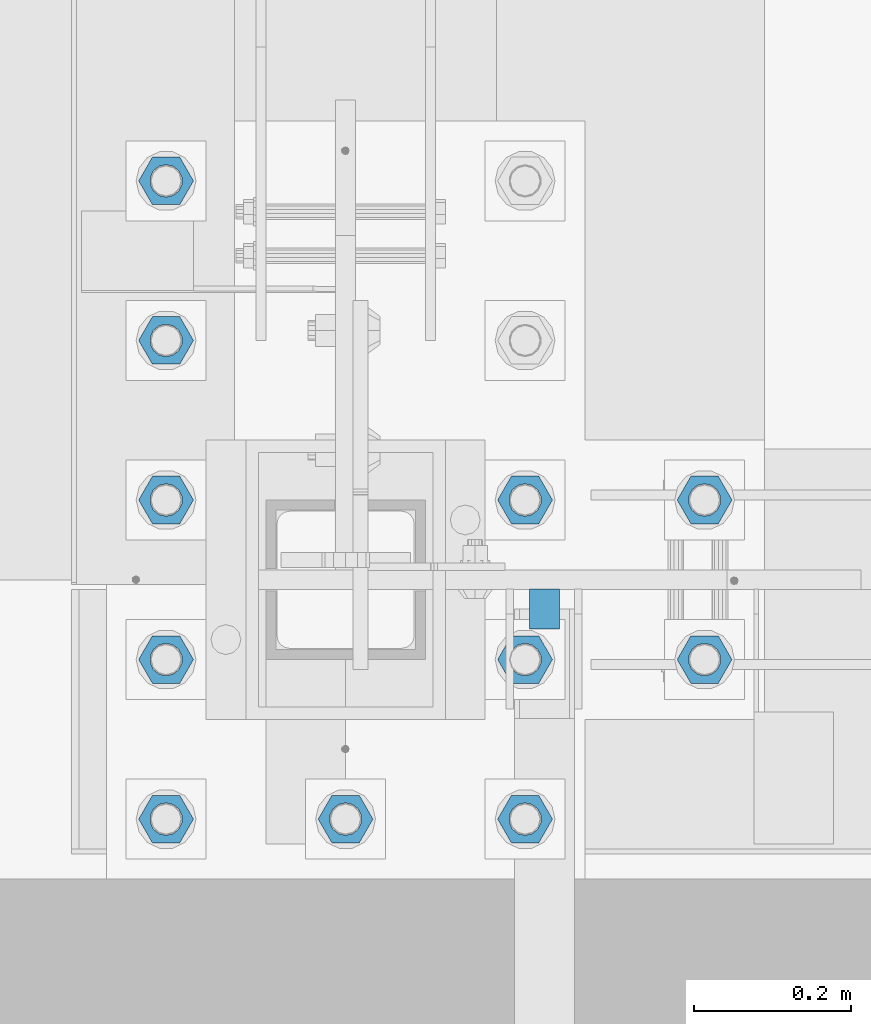
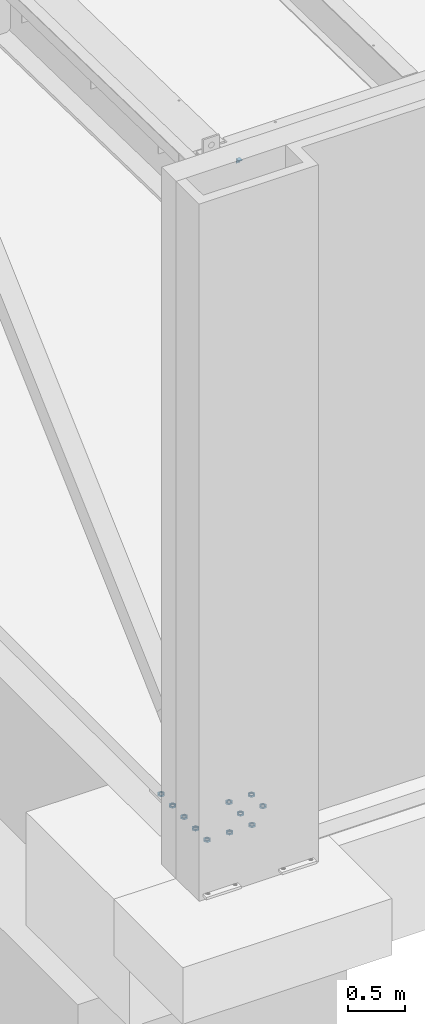
# One storey, part 1386 of 1763: 12 beams, 2 elements without a shape of their own.
"""IFC2X3 building model written with IfcOpenShell, lengths in millimetres."""

from ifc_helpers import new_model, si_unit, frame, origin_with_axes, place, context, subcontext, project, spatial, faceted_brep, material, type_object, element, aggregate, save


model = new_model("IFC2X3")

# Units and contexts
model_context = context("Model", 3, precision=1e-05, world=origin_with_axes())
body_context = subcontext(model_context, "Body", "Model", "MODEL_VIEW")
ifc_project = project(units=[si_unit("LENGTHUNIT", "METRE", prefix="MILLI"), si_unit("AREAUNIT", "SQUARE_METRE"), si_unit("VOLUMEUNIT", "CUBIC_METRE"), si_unit("MASSUNIT", "GRAM", prefix="KILO"), si_unit("TIMEUNIT", "SECOND"), si_unit("PLANEANGLEUNIT", "RADIAN"), si_unit("SOLIDANGLEUNIT", "STERADIAN"), si_unit("THERMODYNAMICTEMPERATUREUNIT", "DEGREE_CELSIUS"), si_unit("LUMINOUSINTENSITYUNIT", "LUMEN")], contexts=[model_context])

# Site, building, storey
site_placement = place(None, origin_with_axes())
site = spatial("IfcSite", under=ifc_project, at=site_placement, CompositionType="ELEMENT")
building_placement = place(site_placement, origin_with_axes())
building = spatial("IfcBuilding", under=site, at=building_placement, Name="Undefined", CompositionType="ELEMENT")
storey_placement = place(building_placement, origin_with_axes())
storey = spatial("IfcBuildingStorey", under=building, at=storey_placement, Name="Undefined", CompositionType="ELEMENT", Elevation=0.0)

# Assembly, beam
assembly_1_placement = place(storey_placement, origin_with_axes())
assembly_1 = element("IfcElementAssembly", 1, at=assembly_1_placement, inside=storey, Name="BEAM", AssemblyPlace="NOTDEFINED", PredefinedType="RIGID_FRAME")
ifc_material_1 = material(Name="STEEL/A36")
beam_type_1 = type_object("IfcBeamType", Name="L2X2X1/4", PredefinedType="NOTDEFINED")
beam_1_placement = place(assembly_1_placement, frame((-87102.9311228713, -13753.3060686171, 12052.3), z_axis=(0.0, 0.0, -1.0), x_axis=(-1.0, 0.0, 0.0)))
beam_1 = element("IfcBeam", 2, at=beam_1_placement, type_object=beam_type_1, material=ifc_material_1, Name="BEAM", ObjectType="L2X2X1/4", context=body_context, shape_type="Brep", body=[
    faceted_brep([(-1.45519152283669e-11, 25.4000000000015, -25.3999999999869), (1.45519152283669e-11, 25.4000000000015, 25.3999999999796), (38.0999999999913, 25.3999999999996, 25.3999999999996), (38.0999999999913, 25.3999999999996, -25.3999999999996), (1.45519152283669e-11, 19.0499999999993, 25.3999999999796), (38.0999999999913, 19.0499999999993, 25.3999999999996), (-7.27595761418343e-12, 19.0499999999993, -19.0499999999956), (38.0999999999913, 19.0499999999993, -19.0499999999993), (-7.27595761418343e-12, -25.4000000000015, -19.0499999999956), (38.0999999999913, -25.3999999999996, -19.0499999999993), (-1.45519152283669e-11, -25.4000000000015, -25.3999999999869), (38.0999999999913, -25.3999999999996, -25.3999999999996)], [[[0, 1, 2, 3]], [[1, 4, 5, 2]], [[4, 6, 7, 5]], [[6, 8, 9, 7]], [[8, 10, 11, 9]], [[10, 0, 3, 11]], [[5, 7, 9, 11, 3, 2]], [[10, 8, 6, 4, 1, 0]]]),
])
aggregate(assembly_1, [beam_1])

# Assembly, beams
assembly_2_placement = place(storey_placement, origin_with_axes())
assembly_2 = element("IfcElementAssembly", 3, at=assembly_2_placement, inside=storey, Name="TEMPLATE", AssemblyPlace="NOTDEFINED", PredefinedType="RIGID_FRAME")
ifc_material_2 = material(Name="STEEL/A563")
beam_type_2 = type_object("IfcBeamType", Name="1-1/2 DIA. HALF_NUT", PredefinedType="NOTDEFINED")
beam_2_placement = place(assembly_2_placement, frame((-86918.2372736984, -13614.4, 5080.00000000001), z_axis=(0.0, 1.0, 0.0), x_axis=(0.0, 0.0, -1.0)))
beam_2 = element("IfcBeam", 4, at=beam_2_placement, type_object=beam_type_2, material=ifc_material_2, Name="NUT", ObjectType="1-1/2 DIA. HALF_NUT", context=body_context, shape_type="Brep", body=[
    faceted_brep([(0.0, -34.9199981689453, 0.0), (0.0, -17.4599990844727, -30.25), (19.0499999999993, -17.4599990844727, -30.25), (19.0499999999993, -34.9199981689453, 0.0), (0.0, 17.4599990844727, -30.25), (19.0499999999993, 17.4599990844727, -30.25), (0.0, 34.9199981689453, 0.0), (19.0499999999993, 34.9199981689453, 0.0), (0.0, 17.4599990844727, 30.25), (19.0499999999993, 17.4599990844727, 30.25), (0.0, -17.4599990844727, 30.25), (19.0499999999993, -17.4599990844727, 30.25), (0.0, 0.0, 20.6399993896484), (0.0, 8.95536011056538, 18.5959968835978), (19.0499999999993, 8.95536011056538, 18.5959968835978), (19.0499999999993, 0.0, 20.6399993896484), (0.0, 16.1370013209453, 12.8688291298167), (19.0499999999993, 16.1370013209453, 12.8688291298167), (0.0, 20.1225115123816, 4.59283194104137), (19.0499999999993, 20.1225115123816, 4.59283194104137), (0.0, 20.1225115123816, -4.59283194104319), (19.0499999999993, 20.1225115123816, -4.59283194104319), (0.0, 16.1370013209453, -12.8688291298167), (19.0499999999993, 16.1370013209453, -12.8688291298167), (0.0, 8.95536011056538, -18.5959968835978), (19.0499999999993, 8.95536011056538, -18.5959968835978), (0.0, 0.0, -20.6399993896484), (19.0499999999993, 0.0, -20.6399993896484), (0.0, -8.95536011056538, -18.5959968835978), (19.0499999999993, -8.95536011056538, -18.5959968835978), (0.0, -16.1370013209453, -12.8688291298167), (19.0499999999993, -16.1370013209453, -12.8688291298167), (0.0, -20.1225115123816, -4.59283194104137), (19.0499999999993, -20.1225115123816, -4.59283194104137), (0.0, -20.1225115123816, 4.59283194104319), (19.0499999999993, -20.1225115123816, 4.59283194104319), (0.0, -16.1370013209453, 12.8688291298167), (19.0499999999993, -16.1370013209453, 12.8688291298167), (0.0, -8.95536011056538, 18.5959968835978), (19.0499999999993, -8.95536011056538, 18.5959968835978)], [[[0, 1, 2, 3]], [[1, 4, 5, 2]], [[4, 6, 7, 5]], [[6, 8, 9, 7]], [[8, 10, 11, 9]], [[10, 0, 3, 11]], [[12, 13, 14, 15]], [[13, 16, 17, 14]], [[16, 18, 19, 17]], [[18, 20, 21, 19]], [[20, 22, 23, 21]], [[22, 24, 25, 23]], [[24, 26, 27, 25]], [[26, 28, 29, 27]], [[28, 30, 31, 29]], [[30, 32, 33, 31]], [[32, 34, 35, 33]], [[34, 36, 37, 35]], [[36, 38, 39, 37]], [[38, 12, 15, 39]], [[5, 7, 9, 11, 3, 2], [17, 19, 21, 23, 25, 27, 29, 31, 33, 35, 37, 39, 15, 14]], [[10, 8, 6, 4, 1, 0], [38, 36, 34, 32, 30, 28, 26, 24, 22, 20, 18, 16, 13, 12]]]),
])
beam_3_placement = place(assembly_2_placement, frame((-86918.2372736984, -13817.6, 5080.00000000001), z_axis=(0.0, 1.0, 0.0), x_axis=(0.0, 0.0, -1.0)))
beam_3 = element("IfcBeam", 5, at=beam_3_placement, type_object=beam_type_2, material=ifc_material_2, Name="NUT", ObjectType="1-1/2 DIA. HALF_NUT", context=body_context, shape_type="Brep", body=[
    faceted_brep([(0.0, -34.9199981689453, 0.0), (0.0, -17.4599990844727, -30.25), (19.0499999999993, -17.4599990844727, -30.25), (19.0499999999993, -34.9199981689453, 0.0), (0.0, 17.4599990844727, -30.25), (19.0499999999993, 17.4599990844727, -30.25), (0.0, 34.9199981689453, 0.0), (19.0499999999993, 34.9199981689453, 0.0), (0.0, 17.4599990844727, 30.25), (19.0499999999993, 17.4599990844727, 30.25), (0.0, -17.4599990844727, 30.25), (19.0499999999993, -17.4599990844727, 30.25), (0.0, 0.0, 20.6399993896484), (0.0, 8.95536011056538, 18.5959968835978), (19.0499999999993, 8.95536011056538, 18.5959968835978), (19.0499999999993, 0.0, 20.6399993896484), (0.0, 16.1370013209453, 12.8688291298167), (19.0499999999993, 16.1370013209453, 12.8688291298167), (0.0, 20.1225115123816, 4.59283194104137), (19.0499999999993, 20.1225115123816, 4.59283194104137), (0.0, 20.1225115123816, -4.59283194104319), (19.0499999999993, 20.1225115123816, -4.59283194104319), (0.0, 16.1370013209453, -12.8688291298167), (19.0499999999993, 16.1370013209453, -12.8688291298167), (0.0, 8.95536011056538, -18.5959968835978), (19.0499999999993, 8.95536011056538, -18.5959968835978), (0.0, 0.0, -20.6399993896484), (19.0499999999993, 0.0, -20.6399993896484), (0.0, -8.95536011056538, -18.5959968835978), (19.0499999999993, -8.95536011056538, -18.5959968835978), (0.0, -16.1370013209453, -12.8688291298167), (19.0499999999993, -16.1370013209453, -12.8688291298167), (0.0, -20.1225115123816, -4.59283194104137), (19.0499999999993, -20.1225115123816, -4.59283194104137), (0.0, -20.1225115123816, 4.59283194104319), (19.0499999999993, -20.1225115123816, 4.59283194104319), (0.0, -16.1370013209453, 12.8688291298167), (19.0499999999993, -16.1370013209453, 12.8688291298167), (0.0, -8.95536011056538, 18.5959968835978), (19.0499999999993, -8.95536011056538, 18.5959968835978)], [[[0, 1, 2, 3]], [[1, 4, 5, 2]], [[4, 6, 7, 5]], [[6, 8, 9, 7]], [[8, 10, 11, 9]], [[10, 0, 3, 11]], [[12, 13, 14, 15]], [[13, 16, 17, 14]], [[16, 18, 19, 17]], [[18, 20, 21, 19]], [[20, 22, 23, 21]], [[22, 24, 25, 23]], [[24, 26, 27, 25]], [[26, 28, 29, 27]], [[28, 30, 31, 29]], [[30, 32, 33, 31]], [[32, 34, 35, 33]], [[34, 36, 37, 35]], [[36, 38, 39, 37]], [[38, 12, 15, 39]], [[5, 7, 9, 11, 3, 2], [17, 19, 21, 23, 25, 27, 29, 31, 33, 35, 37, 39, 15, 14]], [[10, 8, 6, 4, 1, 0], [38, 36, 34, 32, 30, 28, 26, 24, 22, 20, 18, 16, 13, 12]]]),
])
beam_4_placement = place(assembly_2_placement, frame((-87375.4372736983, -14020.8, 5080.00000000001), z_axis=(0.0, -1.0, 0.0), x_axis=(0.0, 0.0, -1.0)))
beam_4 = element("IfcBeam", 6, at=beam_4_placement, type_object=beam_type_2, material=ifc_material_2, Name="NUT", ObjectType="1-1/2 DIA. HALF_NUT", context=body_context, shape_type="Brep", body=[
    faceted_brep([(0.0, -34.9199981689453, 0.0), (0.0, -17.4599990844727, -30.25), (19.0499999999993, -17.4599990844727, -30.25), (19.0499999999993, -34.9199981689453, 0.0), (0.0, 17.4599990844727, -30.25), (19.0499999999993, 17.4599990844727, -30.25), (0.0, 34.9199981689453, 0.0), (19.0499999999993, 34.9199981689453, 0.0), (0.0, 17.4599990844727, 30.25), (19.0499999999993, 17.4599990844727, 30.25), (0.0, -17.4599990844727, 30.25), (19.0499999999993, -17.4599990844727, 30.25), (0.0, 0.0, 20.6399993896484), (0.0, 8.95536011056538, 18.5959968835978), (19.0499999999993, 8.95536011056538, 18.5959968835978), (19.0499999999993, 0.0, 20.6399993896484), (0.0, 16.1370013209453, 12.8688291298167), (19.0499999999993, 16.1370013209453, 12.8688291298167), (0.0, 20.1225115123816, 4.59283194104137), (19.0499999999993, 20.1225115123816, 4.59283194104137), (0.0, 20.1225115123816, -4.59283194104319), (19.0499999999993, 20.1225115123816, -4.59283194104319), (0.0, 16.1370013209453, -12.8688291298167), (19.0499999999993, 16.1370013209453, -12.8688291298167), (0.0, 8.95536011056538, -18.5959968835978), (19.0499999999993, 8.95536011056538, -18.5959968835978), (0.0, 0.0, -20.6399993896484), (19.0499999999993, 0.0, -20.6399993896484), (0.0, -8.95536011056538, -18.5959968835978), (19.0499999999993, -8.95536011056538, -18.5959968835978), (0.0, -16.1370013209453, -12.8688291298167), (19.0499999999993, -16.1370013209453, -12.8688291298167), (0.0, -20.1225115123816, -4.59283194104137), (19.0499999999993, -20.1225115123816, -4.59283194104137), (0.0, -20.1225115123816, 4.59283194104319), (19.0499999999993, -20.1225115123816, 4.59283194104319), (0.0, -16.1370013209453, 12.8688291298167), (19.0499999999993, -16.1370013209453, 12.8688291298167), (0.0, -8.95536011056538, 18.5959968835978), (19.0499999999993, -8.95536011056538, 18.5959968835978)], [[[0, 1, 2, 3]], [[1, 4, 5, 2]], [[4, 6, 7, 5]], [[6, 8, 9, 7]], [[8, 10, 11, 9]], [[10, 0, 3, 11]], [[12, 13, 14, 15]], [[13, 16, 17, 14]], [[16, 18, 19, 17]], [[18, 20, 21, 19]], [[20, 22, 23, 21]], [[22, 24, 25, 23]], [[24, 26, 27, 25]], [[26, 28, 29, 27]], [[28, 30, 31, 29]], [[30, 32, 33, 31]], [[32, 34, 35, 33]], [[34, 36, 37, 35]], [[36, 38, 39, 37]], [[38, 12, 15, 39]], [[5, 7, 9, 11, 3, 2], [17, 19, 21, 23, 25, 27, 29, 31, 33, 35, 37, 39, 15, 14]], [[10, 8, 6, 4, 1, 0], [38, 36, 34, 32, 30, 28, 26, 24, 22, 20, 18, 16, 13, 12]]]),
])
beam_5_placement = place(assembly_2_placement, frame((-87146.8372736983, -13817.6, 5080.00000000001), z_axis=(0.0, 1.0, 0.0), x_axis=(0.0, 0.0, -1.0)))
beam_5 = element("IfcBeam", 7, at=beam_5_placement, type_object=beam_type_2, material=ifc_material_2, Name="NUT", ObjectType="1-1/2 DIA. HALF_NUT", context=body_context, shape_type="Brep", body=[
    faceted_brep([(0.0, -34.9199981689453, 0.0), (0.0, -17.4599990844727, -30.25), (19.0499999999993, -17.4599990844727, -30.25), (19.0499999999993, -34.9199981689453, 0.0), (0.0, 17.4599990844727, -30.25), (19.0499999999993, 17.4599990844727, -30.25), (0.0, 34.9199981689453, 0.0), (19.0499999999993, 34.9199981689453, 0.0), (0.0, 17.4599990844727, 30.25), (19.0499999999993, 17.4599990844727, 30.25), (0.0, -17.4599990844727, 30.25), (19.0499999999993, -17.4599990844727, 30.25), (0.0, 0.0, 20.6399993896484), (0.0, 8.95536011056538, 18.5959968835978), (19.0499999999993, 8.95536011056538, 18.5959968835978), (19.0499999999993, 0.0, 20.6399993896484), (0.0, 16.1370013209453, 12.8688291298167), (19.0499999999993, 16.1370013209453, 12.8688291298167), (0.0, 20.1225115123816, 4.59283194104137), (19.0499999999993, 20.1225115123816, 4.59283194104137), (0.0, 20.1225115123816, -4.59283194104319), (19.0499999999993, 20.1225115123816, -4.59283194104319), (0.0, 16.1370013209453, -12.8688291298167), (19.0499999999993, 16.1370013209453, -12.8688291298167), (0.0, 8.95536011056538, -18.5959968835978), (19.0499999999993, 8.95536011056538, -18.5959968835978), (0.0, 0.0, -20.6399993896484), (19.0499999999993, 0.0, -20.6399993896484), (0.0, -8.95536011056538, -18.5959968835978), (19.0499999999993, -8.95536011056538, -18.5959968835978), (0.0, -16.1370013209453, -12.8688291298167), (19.0499999999993, -16.1370013209453, -12.8688291298167), (0.0, -20.1225115123816, -4.59283194104137), (19.0499999999993, -20.1225115123816, -4.59283194104137), (0.0, -20.1225115123816, 4.59283194104319), (19.0499999999993, -20.1225115123816, 4.59283194104319), (0.0, -16.1370013209453, 12.8688291298167), (19.0499999999993, -16.1370013209453, 12.8688291298167), (0.0, -8.95536011056538, 18.5959968835978), (19.0499999999993, -8.95536011056538, 18.5959968835978)], [[[0, 1, 2, 3]], [[1, 4, 5, 2]], [[4, 6, 7, 5]], [[6, 8, 9, 7]], [[8, 10, 11, 9]], [[10, 0, 3, 11]], [[12, 13, 14, 15]], [[13, 16, 17, 14]], [[16, 18, 19, 17]], [[18, 20, 21, 19]], [[20, 22, 23, 21]], [[22, 24, 25, 23]], [[24, 26, 27, 25]], [[26, 28, 29, 27]], [[28, 30, 31, 29]], [[30, 32, 33, 31]], [[32, 34, 35, 33]], [[34, 36, 37, 35]], [[36, 38, 39, 37]], [[38, 12, 15, 39]], [[5, 7, 9, 11, 3, 2], [17, 19, 21, 23, 25, 27, 29, 31, 33, 35, 37, 39, 15, 14]], [[10, 8, 6, 4, 1, 0], [38, 36, 34, 32, 30, 28, 26, 24, 22, 20, 18, 16, 13, 12]]]),
])
beam_6_placement = place(assembly_2_placement, frame((-87146.8372736983, -14020.8, 5080.00000000001), z_axis=(0.0, 1.0, 0.0), x_axis=(0.0, 0.0, -1.0)))
beam_6 = element("IfcBeam", 8, at=beam_6_placement, type_object=beam_type_2, material=ifc_material_2, Name="NUT", ObjectType="1-1/2 DIA. HALF_NUT", context=body_context, shape_type="Brep", body=[
    faceted_brep([(0.0, -34.9199981689453, 0.0), (0.0, -17.4599990844727, -30.25), (19.0499999999993, -17.4599990844727, -30.25), (19.0499999999993, -34.9199981689453, 0.0), (0.0, 17.4599990844727, -30.25), (19.0499999999993, 17.4599990844727, -30.25), (0.0, 34.9199981689453, 0.0), (19.0499999999993, 34.9199981689453, 0.0), (0.0, 17.4599990844727, 30.25), (19.0499999999993, 17.4599990844727, 30.25), (0.0, -17.4599990844727, 30.25), (19.0499999999993, -17.4599990844727, 30.25), (0.0, 0.0, 20.6399993896484), (0.0, 8.95536011056538, 18.5959968835978), (19.0499999999993, 8.95536011056538, 18.5959968835978), (19.0499999999993, 0.0, 20.6399993896484), (0.0, 16.1370013209453, 12.8688291298167), (19.0499999999993, 16.1370013209453, 12.8688291298167), (0.0, 20.1225115123816, 4.59283194104137), (19.0499999999993, 20.1225115123816, 4.59283194104137), (0.0, 20.1225115123816, -4.59283194104319), (19.0499999999993, 20.1225115123816, -4.59283194104319), (0.0, 16.1370013209453, -12.8688291298167), (19.0499999999993, 16.1370013209453, -12.8688291298167), (0.0, 8.95536011056538, -18.5959968835978), (19.0499999999993, 8.95536011056538, -18.5959968835978), (0.0, 0.0, -20.6399993896484), (19.0499999999993, 0.0, -20.6399993896484), (0.0, -8.95536011056538, -18.5959968835978), (19.0499999999993, -8.95536011056538, -18.5959968835978), (0.0, -16.1370013209453, -12.8688291298167), (19.0499999999993, -16.1370013209453, -12.8688291298167), (0.0, -20.1225115123816, -4.59283194104137), (19.0499999999993, -20.1225115123816, -4.59283194104137), (0.0, -20.1225115123816, 4.59283194104319), (19.0499999999993, -20.1225115123816, 4.59283194104319), (0.0, -16.1370013209453, 12.8688291298167), (19.0499999999993, -16.1370013209453, 12.8688291298167), (0.0, -8.95536011056538, 18.5959968835978), (19.0499999999993, -8.95536011056538, 18.5959968835978)], [[[0, 1, 2, 3]], [[1, 4, 5, 2]], [[4, 6, 7, 5]], [[6, 8, 9, 7]], [[8, 10, 11, 9]], [[10, 0, 3, 11]], [[12, 13, 14, 15]], [[13, 16, 17, 14]], [[16, 18, 19, 17]], [[18, 20, 21, 19]], [[20, 22, 23, 21]], [[22, 24, 25, 23]], [[24, 26, 27, 25]], [[26, 28, 29, 27]], [[28, 30, 31, 29]], [[30, 32, 33, 31]], [[32, 34, 35, 33]], [[34, 36, 37, 35]], [[36, 38, 39, 37]], [[38, 12, 15, 39]], [[5, 7, 9, 11, 3, 2], [17, 19, 21, 23, 25, 27, 29, 31, 33, 35, 37, 39, 15, 14]], [[10, 8, 6, 4, 1, 0], [38, 36, 34, 32, 30, 28, 26, 24, 22, 20, 18, 16, 13, 12]]]),
])
beam_7_placement = place(assembly_2_placement, frame((-87604.0372736983, -14020.8, 5080.00000000001), z_axis=(0.0, -1.0, 0.0), x_axis=(0.0, 0.0, -1.0)))
beam_7 = element("IfcBeam", 9, at=beam_7_placement, type_object=beam_type_2, material=ifc_material_2, Name="NUT", ObjectType="1-1/2 DIA. HALF_NUT", context=body_context, shape_type="Brep", body=[
    faceted_brep([(0.0, -34.9199981689453, 0.0), (0.0, -17.4599990844727, -30.25), (19.0499999999993, -17.4599990844727, -30.25), (19.0499999999993, -34.9199981689453, 0.0), (0.0, 17.4599990844727, -30.25), (19.0499999999993, 17.4599990844727, -30.25), (0.0, 34.9199981689453, 0.0), (19.0499999999993, 34.9199981689453, 0.0), (0.0, 17.4599990844727, 30.25), (19.0499999999993, 17.4599990844727, 30.25), (0.0, -17.4599990844727, 30.25), (19.0499999999993, -17.4599990844727, 30.25), (0.0, 0.0, 20.6399993896484), (0.0, 8.95536011056538, 18.5959968835978), (19.0499999999993, 8.95536011056538, 18.5959968835978), (19.0499999999993, 0.0, 20.6399993896484), (0.0, 16.1370013209453, 12.8688291298167), (19.0499999999993, 16.1370013209453, 12.8688291298167), (0.0, 20.1225115123816, 4.59283194104137), (19.0499999999993, 20.1225115123816, 4.59283194104137), (0.0, 20.1225115123816, -4.59283194104319), (19.0499999999993, 20.1225115123816, -4.59283194104319), (0.0, 16.1370013209453, -12.8688291298167), (19.0499999999993, 16.1370013209453, -12.8688291298167), (0.0, 8.95536011056538, -18.5959968835978), (19.0499999999993, 8.95536011056538, -18.5959968835978), (0.0, 0.0, -20.6399993896484), (19.0499999999993, 0.0, -20.6399993896484), (0.0, -8.95536011056538, -18.5959968835978), (19.0499999999993, -8.95536011056538, -18.5959968835978), (0.0, -16.1370013209453, -12.8688291298167), (19.0499999999993, -16.1370013209453, -12.8688291298167), (0.0, -20.1225115123816, -4.59283194104137), (19.0499999999993, -20.1225115123816, -4.59283194104137), (0.0, -20.1225115123816, 4.59283194104319), (19.0499999999993, -20.1225115123816, 4.59283194104319), (0.0, -16.1370013209453, 12.8688291298167), (19.0499999999993, -16.1370013209453, 12.8688291298167), (0.0, -8.95536011056538, 18.5959968835978), (19.0499999999993, -8.95536011056538, 18.5959968835978)], [[[0, 1, 2, 3]], [[1, 4, 5, 2]], [[4, 6, 7, 5]], [[6, 8, 9, 7]], [[8, 10, 11, 9]], [[10, 0, 3, 11]], [[12, 13, 14, 15]], [[13, 16, 17, 14]], [[16, 18, 19, 17]], [[18, 20, 21, 19]], [[20, 22, 23, 21]], [[22, 24, 25, 23]], [[24, 26, 27, 25]], [[26, 28, 29, 27]], [[28, 30, 31, 29]], [[30, 32, 33, 31]], [[32, 34, 35, 33]], [[34, 36, 37, 35]], [[36, 38, 39, 37]], [[38, 12, 15, 39]], [[5, 7, 9, 11, 3, 2], [17, 19, 21, 23, 25, 27, 29, 31, 33, 35, 37, 39, 15, 14]], [[10, 8, 6, 4, 1, 0], [38, 36, 34, 32, 30, 28, 26, 24, 22, 20, 18, 16, 13, 12]]]),
])
beam_8_placement = place(assembly_2_placement, frame((-87146.8372736983, -13614.4, 5080.00000000001), z_axis=(0.0, 1.0, 0.0), x_axis=(0.0, 0.0, -1.0)))
beam_8 = element("IfcBeam", 10, at=beam_8_placement, type_object=beam_type_2, material=ifc_material_2, Name="NUT", ObjectType="1-1/2 DIA. HALF_NUT", context=body_context, shape_type="Brep", body=[
    faceted_brep([(0.0, -34.9199981689453, 0.0), (0.0, -17.4599990844727, -30.25), (19.0499999999993, -17.4599990844727, -30.25), (19.0499999999993, -34.9199981689453, 0.0), (0.0, 17.4599990844727, -30.25), (19.0499999999993, 17.4599990844727, -30.25), (0.0, 34.9199981689453, 0.0), (19.0499999999993, 34.9199981689453, 0.0), (0.0, 17.4599990844727, 30.25), (19.0499999999993, 17.4599990844727, 30.25), (0.0, -17.4599990844727, 30.25), (19.0499999999993, -17.4599990844727, 30.25), (0.0, 0.0, 20.6399993896484), (0.0, 8.95536011056538, 18.5959968835978), (19.0499999999993, 8.95536011056538, 18.5959968835978), (19.0499999999993, 0.0, 20.6399993896484), (0.0, 16.1370013209453, 12.8688291298167), (19.0499999999993, 16.1370013209453, 12.8688291298167), (0.0, 20.1225115123816, 4.59283194104137), (19.0499999999993, 20.1225115123816, 4.59283194104137), (0.0, 20.1225115123816, -4.59283194104319), (19.0499999999993, 20.1225115123816, -4.59283194104319), (0.0, 16.1370013209453, -12.8688291298167), (19.0499999999993, 16.1370013209453, -12.8688291298167), (0.0, 8.95536011056538, -18.5959968835978), (19.0499999999993, 8.95536011056538, -18.5959968835978), (0.0, 0.0, -20.6399993896484), (19.0499999999993, 0.0, -20.6399993896484), (0.0, -8.95536011056538, -18.5959968835978), (19.0499999999993, -8.95536011056538, -18.5959968835978), (0.0, -16.1370013209453, -12.8688291298167), (19.0499999999993, -16.1370013209453, -12.8688291298167), (0.0, -20.1225115123816, -4.59283194104137), (19.0499999999993, -20.1225115123816, -4.59283194104137), (0.0, -20.1225115123816, 4.59283194104319), (19.0499999999993, -20.1225115123816, 4.59283194104319), (0.0, -16.1370013209453, 12.8688291298167), (19.0499999999993, -16.1370013209453, 12.8688291298167), (0.0, -8.95536011056538, 18.5959968835978), (19.0499999999993, -8.95536011056538, 18.5959968835978)], [[[0, 1, 2, 3]], [[1, 4, 5, 2]], [[4, 6, 7, 5]], [[6, 8, 9, 7]], [[8, 10, 11, 9]], [[10, 0, 3, 11]], [[12, 13, 14, 15]], [[13, 16, 17, 14]], [[16, 18, 19, 17]], [[18, 20, 21, 19]], [[20, 22, 23, 21]], [[22, 24, 25, 23]], [[24, 26, 27, 25]], [[26, 28, 29, 27]], [[28, 30, 31, 29]], [[30, 32, 33, 31]], [[32, 34, 35, 33]], [[34, 36, 37, 35]], [[36, 38, 39, 37]], [[38, 12, 15, 39]], [[5, 7, 9, 11, 3, 2], [17, 19, 21, 23, 25, 27, 29, 31, 33, 35, 37, 39, 15, 14]], [[10, 8, 6, 4, 1, 0], [38, 36, 34, 32, 30, 28, 26, 24, 22, 20, 18, 16, 13, 12]]]),
])
beam_9_placement = place(assembly_2_placement, frame((-87604.0372736983, -13817.6, 5080.00000000001), z_axis=(0.0, -1.0, 0.0), x_axis=(0.0, 0.0, -1.0)))
beam_9 = element("IfcBeam", 11, at=beam_9_placement, type_object=beam_type_2, material=ifc_material_2, Name="NUT", ObjectType="1-1/2 DIA. HALF_NUT", context=body_context, shape_type="Brep", body=[
    faceted_brep([(0.0, -34.9199981689453, 0.0), (0.0, -17.4599990844727, -30.25), (19.0499999999993, -17.4599990844727, -30.25), (19.0499999999993, -34.9199981689453, 0.0), (0.0, 17.4599990844727, -30.25), (19.0499999999993, 17.4599990844727, -30.25), (0.0, 34.9199981689453, 0.0), (19.0499999999993, 34.9199981689453, 0.0), (0.0, 17.4599990844727, 30.25), (19.0499999999993, 17.4599990844727, 30.25), (0.0, -17.4599990844727, 30.25), (19.0499999999993, -17.4599990844727, 30.25), (0.0, 0.0, 20.6399993896484), (0.0, 8.95536011056538, 18.5959968835978), (19.0499999999993, 8.95536011056538, 18.5959968835978), (19.0499999999993, 0.0, 20.6399993896484), (0.0, 16.1370013209453, 12.8688291298167), (19.0499999999993, 16.1370013209453, 12.8688291298167), (0.0, 20.1225115123816, 4.59283194104137), (19.0499999999993, 20.1225115123816, 4.59283194104137), (0.0, 20.1225115123816, -4.59283194104319), (19.0499999999993, 20.1225115123816, -4.59283194104319), (0.0, 16.1370013209453, -12.8688291298167), (19.0499999999993, 16.1370013209453, -12.8688291298167), (0.0, 8.95536011056538, -18.5959968835978), (19.0499999999993, 8.95536011056538, -18.5959968835978), (0.0, 0.0, -20.6399993896484), (19.0499999999993, 0.0, -20.6399993896484), (0.0, -8.95536011056538, -18.5959968835978), (19.0499999999993, -8.95536011056538, -18.5959968835978), (0.0, -16.1370013209453, -12.8688291298167), (19.0499999999993, -16.1370013209453, -12.8688291298167), (0.0, -20.1225115123816, -4.59283194104137), (19.0499999999993, -20.1225115123816, -4.59283194104137), (0.0, -20.1225115123816, 4.59283194104319), (19.0499999999993, -20.1225115123816, 4.59283194104319), (0.0, -16.1370013209453, 12.8688291298167), (19.0499999999993, -16.1370013209453, 12.8688291298167), (0.0, -8.95536011056538, 18.5959968835978), (19.0499999999993, -8.95536011056538, 18.5959968835978)], [[[0, 1, 2, 3]], [[1, 4, 5, 2]], [[4, 6, 7, 5]], [[6, 8, 9, 7]], [[8, 10, 11, 9]], [[10, 0, 3, 11]], [[12, 13, 14, 15]], [[13, 16, 17, 14]], [[16, 18, 19, 17]], [[18, 20, 21, 19]], [[20, 22, 23, 21]], [[22, 24, 25, 23]], [[24, 26, 27, 25]], [[26, 28, 29, 27]], [[28, 30, 31, 29]], [[30, 32, 33, 31]], [[32, 34, 35, 33]], [[34, 36, 37, 35]], [[36, 38, 39, 37]], [[38, 12, 15, 39]], [[5, 7, 9, 11, 3, 2], [17, 19, 21, 23, 25, 27, 29, 31, 33, 35, 37, 39, 15, 14]], [[10, 8, 6, 4, 1, 0], [38, 36, 34, 32, 30, 28, 26, 24, 22, 20, 18, 16, 13, 12]]]),
])
beam_10_placement = place(assembly_2_placement, frame((-87604.0372736983, -13614.4, 5080.00000000001), z_axis=(0.0, -1.0, 0.0), x_axis=(0.0, 0.0, -1.0)))
beam_10 = element("IfcBeam", 12, at=beam_10_placement, type_object=beam_type_2, material=ifc_material_2, Name="NUT", ObjectType="1-1/2 DIA. HALF_NUT", context=body_context, shape_type="Brep", body=[
    faceted_brep([(0.0, -34.9199981689453, 0.0), (0.0, -17.4599990844727, -30.25), (19.0499999999993, -17.4599990844727, -30.25), (19.0499999999993, -34.9199981689453, 0.0), (0.0, 17.4599990844727, -30.25), (19.0499999999993, 17.4599990844727, -30.25), (0.0, 34.9199981689453, 0.0), (19.0499999999993, 34.9199981689453, 0.0), (0.0, 17.4599990844727, 30.25), (19.0499999999993, 17.4599990844727, 30.25), (0.0, -17.4599990844727, 30.25), (19.0499999999993, -17.4599990844727, 30.25), (0.0, 0.0, 20.6399993896484), (0.0, 8.95536011056538, 18.5959968835978), (19.0499999999993, 8.95536011056538, 18.5959968835978), (19.0499999999993, 0.0, 20.6399993896484), (0.0, 16.1370013209453, 12.8688291298167), (19.0499999999993, 16.1370013209453, 12.8688291298167), (0.0, 20.1225115123816, 4.59283194104137), (19.0499999999993, 20.1225115123816, 4.59283194104137), (0.0, 20.1225115123816, -4.59283194104319), (19.0499999999993, 20.1225115123816, -4.59283194104319), (0.0, 16.1370013209453, -12.8688291298167), (19.0499999999993, 16.1370013209453, -12.8688291298167), (0.0, 8.95536011056538, -18.5959968835978), (19.0499999999993, 8.95536011056538, -18.5959968835978), (0.0, 0.0, -20.6399993896484), (19.0499999999993, 0.0, -20.6399993896484), (0.0, -8.95536011056538, -18.5959968835978), (19.0499999999993, -8.95536011056538, -18.5959968835978), (0.0, -16.1370013209453, -12.8688291298167), (19.0499999999993, -16.1370013209453, -12.8688291298167), (0.0, -20.1225115123816, -4.59283194104137), (19.0499999999993, -20.1225115123816, -4.59283194104137), (0.0, -20.1225115123816, 4.59283194104319), (19.0499999999993, -20.1225115123816, 4.59283194104319), (0.0, -16.1370013209453, 12.8688291298167), (19.0499999999993, -16.1370013209453, 12.8688291298167), (0.0, -8.95536011056538, 18.5959968835978), (19.0499999999993, -8.95536011056538, 18.5959968835978)], [[[0, 1, 2, 3]], [[1, 4, 5, 2]], [[4, 6, 7, 5]], [[6, 8, 9, 7]], [[8, 10, 11, 9]], [[10, 0, 3, 11]], [[12, 13, 14, 15]], [[13, 16, 17, 14]], [[16, 18, 19, 17]], [[18, 20, 21, 19]], [[20, 22, 23, 21]], [[22, 24, 25, 23]], [[24, 26, 27, 25]], [[26, 28, 29, 27]], [[28, 30, 31, 29]], [[30, 32, 33, 31]], [[32, 34, 35, 33]], [[34, 36, 37, 35]], [[36, 38, 39, 37]], [[38, 12, 15, 39]], [[5, 7, 9, 11, 3, 2], [17, 19, 21, 23, 25, 27, 29, 31, 33, 35, 37, 39, 15, 14]], [[10, 8, 6, 4, 1, 0], [38, 36, 34, 32, 30, 28, 26, 24, 22, 20, 18, 16, 13, 12]]]),
])
beam_11_placement = place(assembly_2_placement, frame((-87604.0372736983, -13411.2, 5080.00000000001), z_axis=(0.0, -1.0, 0.0), x_axis=(0.0, 0.0, -1.0)))
beam_11 = element("IfcBeam", 13, at=beam_11_placement, type_object=beam_type_2, material=ifc_material_2, Name="NUT", ObjectType="1-1/2 DIA. HALF_NUT", context=body_context, shape_type="Brep", body=[
    faceted_brep([(0.0, -34.9199981689453, 0.0), (0.0, -17.4599990844727, -30.25), (19.0499999999993, -17.4599990844727, -30.25), (19.0499999999993, -34.9199981689453, 0.0), (0.0, 17.4599990844727, -30.25), (19.0499999999993, 17.4599990844727, -30.25), (0.0, 34.9199981689453, 0.0), (19.0499999999993, 34.9199981689453, 0.0), (0.0, 17.4599990844727, 30.25), (19.0499999999993, 17.4599990844727, 30.25), (0.0, -17.4599990844727, 30.25), (19.0499999999993, -17.4599990844727, 30.25), (0.0, 0.0, 20.6399993896484), (0.0, 8.95536011056538, 18.5959968835978), (19.0499999999993, 8.95536011056538, 18.5959968835978), (19.0499999999993, 0.0, 20.6399993896484), (0.0, 16.1370013209453, 12.8688291298167), (19.0499999999993, 16.1370013209453, 12.8688291298167), (0.0, 20.1225115123816, 4.59283194104137), (19.0499999999993, 20.1225115123816, 4.59283194104137), (0.0, 20.1225115123816, -4.59283194104319), (19.0499999999993, 20.1225115123816, -4.59283194104319), (0.0, 16.1370013209453, -12.8688291298167), (19.0499999999993, 16.1370013209453, -12.8688291298167), (0.0, 8.95536011056538, -18.5959968835978), (19.0499999999993, 8.95536011056538, -18.5959968835978), (0.0, 0.0, -20.6399993896484), (19.0499999999993, 0.0, -20.6399993896484), (0.0, -8.95536011056538, -18.5959968835978), (19.0499999999993, -8.95536011056538, -18.5959968835978), (0.0, -16.1370013209453, -12.8688291298167), (19.0499999999993, -16.1370013209453, -12.8688291298167), (0.0, -20.1225115123816, -4.59283194104137), (19.0499999999993, -20.1225115123816, -4.59283194104137), (0.0, -20.1225115123816, 4.59283194104319), (19.0499999999993, -20.1225115123816, 4.59283194104319), (0.0, -16.1370013209453, 12.8688291298167), (19.0499999999993, -16.1370013209453, 12.8688291298167), (0.0, -8.95536011056538, 18.5959968835978), (19.0499999999993, -8.95536011056538, 18.5959968835978)], [[[0, 1, 2, 3]], [[1, 4, 5, 2]], [[4, 6, 7, 5]], [[6, 8, 9, 7]], [[8, 10, 11, 9]], [[10, 0, 3, 11]], [[12, 13, 14, 15]], [[13, 16, 17, 14]], [[16, 18, 19, 17]], [[18, 20, 21, 19]], [[20, 22, 23, 21]], [[22, 24, 25, 23]], [[24, 26, 27, 25]], [[26, 28, 29, 27]], [[28, 30, 31, 29]], [[30, 32, 33, 31]], [[32, 34, 35, 33]], [[34, 36, 37, 35]], [[36, 38, 39, 37]], [[38, 12, 15, 39]], [[5, 7, 9, 11, 3, 2], [17, 19, 21, 23, 25, 27, 29, 31, 33, 35, 37, 39, 15, 14]], [[10, 8, 6, 4, 1, 0], [38, 36, 34, 32, 30, 28, 26, 24, 22, 20, 18, 16, 13, 12]]]),
])
beam_12_placement = place(assembly_2_placement, frame((-87604.0372736983, -13208.0, 5080.00000000001), z_axis=(0.0, -1.0, 0.0), x_axis=(0.0, 0.0, -1.0)))
beam_12 = element("IfcBeam", 14, at=beam_12_placement, type_object=beam_type_2, material=ifc_material_2, Name="NUT", ObjectType="1-1/2 DIA. HALF_NUT", context=body_context, shape_type="Brep", body=[
    faceted_brep([(0.0, -34.9199981689453, 0.0), (0.0, -17.4599990844727, -30.25), (19.0499999999993, -17.4599990844727, -30.25), (19.0499999999993, -34.9199981689453, 0.0), (0.0, 17.4599990844727, -30.25), (19.0499999999993, 17.4599990844727, -30.25), (0.0, 34.9199981689453, 0.0), (19.0499999999993, 34.9199981689453, 0.0), (0.0, 17.4599990844727, 30.25), (19.0499999999993, 17.4599990844727, 30.25), (0.0, -17.4599990844727, 30.25), (19.0499999999993, -17.4599990844727, 30.25), (0.0, 0.0, 20.6399993896484), (0.0, 8.95536011056538, 18.5959968835978), (19.0499999999993, 8.95536011056538, 18.5959968835978), (19.0499999999993, 0.0, 20.6399993896484), (0.0, 16.1370013209453, 12.8688291298167), (19.0499999999993, 16.1370013209453, 12.8688291298167), (0.0, 20.1225115123816, 4.59283194104137), (19.0499999999993, 20.1225115123816, 4.59283194104137), (0.0, 20.1225115123816, -4.59283194104319), (19.0499999999993, 20.1225115123816, -4.59283194104319), (0.0, 16.1370013209453, -12.8688291298167), (19.0499999999993, 16.1370013209453, -12.8688291298167), (0.0, 8.95536011056538, -18.5959968835978), (19.0499999999993, 8.95536011056538, -18.5959968835978), (0.0, 0.0, -20.6399993896484), (19.0499999999993, 0.0, -20.6399993896484), (0.0, -8.95536011056538, -18.5959968835978), (19.0499999999993, -8.95536011056538, -18.5959968835978), (0.0, -16.1370013209453, -12.8688291298167), (19.0499999999993, -16.1370013209453, -12.8688291298167), (0.0, -20.1225115123816, -4.59283194104137), (19.0499999999993, -20.1225115123816, -4.59283194104137), (0.0, -20.1225115123816, 4.59283194104319), (19.0499999999993, -20.1225115123816, 4.59283194104319), (0.0, -16.1370013209453, 12.8688291298167), (19.0499999999993, -16.1370013209453, 12.8688291298167), (0.0, -8.95536011056538, 18.5959968835978), (19.0499999999993, -8.95536011056538, 18.5959968835978)], [[[0, 1, 2, 3]], [[1, 4, 5, 2]], [[4, 6, 7, 5]], [[6, 8, 9, 7]], [[8, 10, 11, 9]], [[10, 0, 3, 11]], [[12, 13, 14, 15]], [[13, 16, 17, 14]], [[16, 18, 19, 17]], [[18, 20, 21, 19]], [[20, 22, 23, 21]], [[22, 24, 25, 23]], [[24, 26, 27, 25]], [[26, 28, 29, 27]], [[28, 30, 31, 29]], [[30, 32, 33, 31]], [[32, 34, 35, 33]], [[34, 36, 37, 35]], [[36, 38, 39, 37]], [[38, 12, 15, 39]], [[5, 7, 9, 11, 3, 2], [17, 19, 21, 23, 25, 27, 29, 31, 33, 35, 37, 39, 15, 14]], [[10, 8, 6, 4, 1, 0], [38, 36, 34, 32, 30, 28, 26, 24, 22, 20, 18, 16, 13, 12]]]),
])
aggregate(assembly_2, [beam_2, beam_3, beam_4, beam_5, beam_6, beam_7, beam_8, beam_9, beam_10, beam_11, beam_12])

save(model, "model.ifc")
